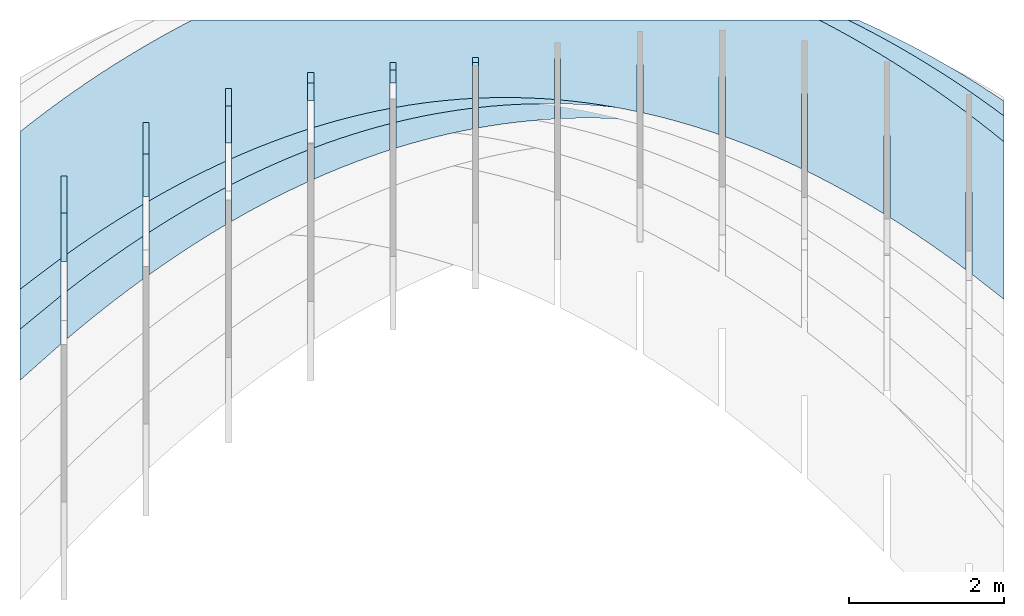
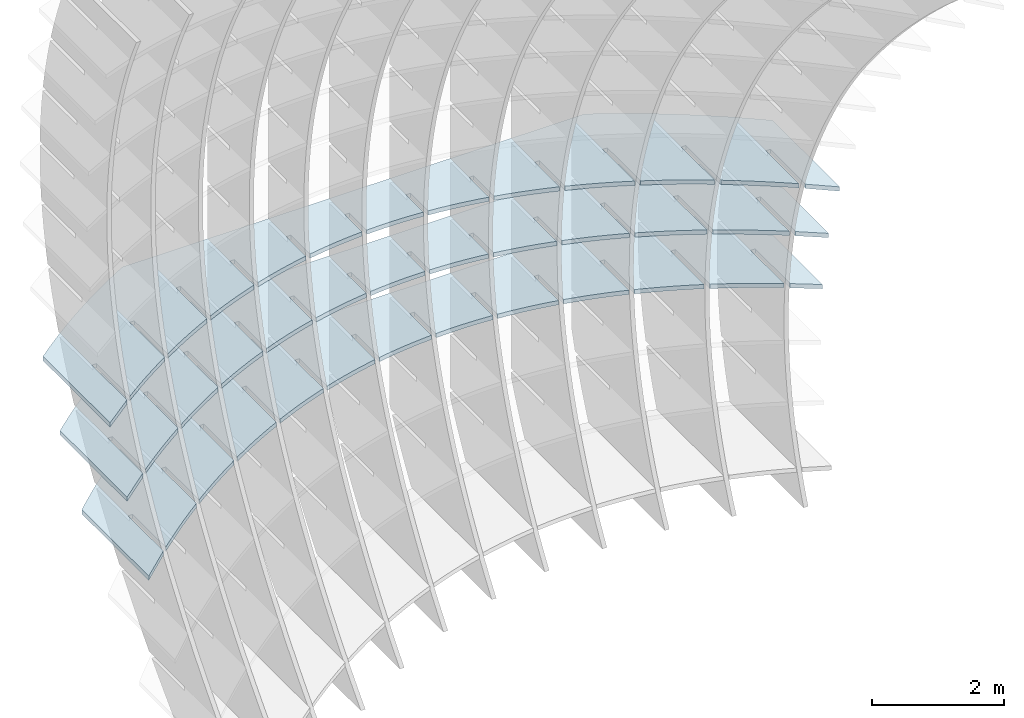
# Not in any storey, part 4 of 9: 3 slabs.
"""IFC2X3 building model written with IfcOpenShell, lengths in metres."""

from ifc_helpers import new_model, si_unit, point, direction, frame, frame_2d, origin_with_axes, place, context, project, spatial, polyline, circle_curve, parameter, trimmed, segment, composite_curve, outline, extrude, material, layer, layer_set, layer_usage, type_object, element, save


model = new_model("IFC2X3")

# Units and contexts
model_context = context("Model", 3, precision=2.54e-06, world=origin_with_axes(), true_north=direction((0.0, 1.0)), identifier="Body")
ifc_project = project(units=[si_unit("LENGTHUNIT", "METRE"), si_unit("AREAUNIT", "SQUARE_METRE"), si_unit("VOLUMEUNIT", "CUBIC_METRE"), si_unit("PLANEANGLEUNIT", "RADIAN")], contexts=[model_context])

# Building
building_placement = place(None, origin_with_axes())
building = spatial("IfcBuilding", under=ifc_project, at=building_placement, Name="Building", CompositionType="ELEMENT")

# Slabs
ifc_material = material(Name="MATERIAL")
ifc_layer = layer(ifc_material, 0.07874, ventilated=True)
ifc_layer_set = layer_set([ifc_layer], Name="SLAB")
ifc_layer_usage_1 = layer_usage(ifc_layer_set, "AXIS3", "NEGATIVE", -0.07874)
slab_type = type_object("IfcSlabType", Name="SLAB", PredefinedType="FLOOR", material=ifc_material)
slab_1_placement = place(None, frame((6.71456553163902, -0.644521735604765, -0.674525377451899), z_axis=(0.0, 0.0, 1.0), x_axis=(-0.79865468, -0.60178958, 0.0)))
element("IfcSlab", 1, at=slab_1_placement, inside=building, type_object=slab_type, material=ifc_layer_usage_1, PredefinedType="FLOOR", context=model_context, shape_type="SweptSolid", body=[
    extrude(outline(composite_curve([segment(polyline([(0.0, 0.0), (0.65981715170106, 0.0)]), True, "CONTINUOUS"), segment(polyline([(0.65981715170106, 0.0), (-0.563019272551403, -1.62286631597352)]), True, "CONTINUOUS"), segment(trimmed(circle_curve(frame_2d((-0.947145737504504, 11.8507513203802), x_axis=(-0.16759298, -0.98585627)), 13.4790921560668), [parameter(0.196889410990906), point((-0.563019272551403, -1.62286631597352))], [parameter(0.0), point((-3.20614692319336, -1.43769625617274))], False, "PARAMETER"), True, "CONTINUOUS"), segment(polyline([(-3.20614692319336, -1.43769625617274), (-9.6696558133236, 3.43258419856068)]), True, "CONTINUOUS"), segment(trimmed(circle_curve(frame_2d((2.6478077793286, 9.33454525857451), x_axis=(-0.97197257, -0.23509427)), 13.6584425799661), [parameter(0.209516548637611), point((-9.6696558133236, 3.43258419856068))], [parameter(0.0), point((-10.627823795437, 6.12352361409473))], False, "PARAMETER"), True, "CONTINUOUS"), segment(polyline([(-10.627823795437, 6.12352361409473), (-9.40498737118473, 7.74638993006891)]), True, "CONTINUOUS"), segment(polyline([(-9.40498737118473, 7.74638993006891), (-9.269961949301, 7.24379688602932)]), True, "CONTINUOUS"), segment(polyline([(-9.269961949301, 7.24379688602932), (-9.91076268291159, 6.39336922031479)]), True, "CONTINUOUS"), segment(polyline([(-9.91076268291159, 6.39336922031479), (-9.84787661316761, 6.345984308875)]), True, "CONTINUOUS"), segment(polyline([(-9.84787661316761, 6.345984308875), (-9.24279514028935, 7.14900777242129)]), True, "CONTINUOUS"), segment(trimmed(circle_curve(frame_2d((4.23850191881597, 11.0342498600031), x_axis=(-0.96089177, -0.27692418)), 14.0299849064409), [parameter(0.0), point((-9.24279514028935, 7.14900777242129))], [parameter(0.0850680879933757), point((-8.86393367696161, 6.01761174932985))], True, "PARAMETER"), True, "CONTINUOUS"), segment(polyline([(-8.86393367696161, 6.01761174932985), (-9.50155817068718, 5.17139937571716)]), True, "CONTINUOUS"), segment(polyline([(-9.50155817068718, 5.17139937571716), (-9.43867210094321, 5.12401446427737)]), True, "CONTINUOUS"), segment(polyline([(-9.43867210094321, 5.12401446427737), (-8.83041447288117, 5.93125310751559)]), True, "CONTINUOUS"), segment(trimmed(circle_curve(frame_2d((2.20317980371444, 10.2436466210628), x_axis=(-0.93138879, -0.36402598)), 11.8463893434332), [parameter(0.0), point((-8.83041447288117, 5.93125310751559))], [parameter(0.0948934985891333), point((-8.37216998538379, 4.90520889880477))], True, "PARAMETER"), True, "CONTINUOUS"), segment(polyline([(-8.37216998538379, 4.90520889880477), (-8.97825059234254, 4.10085945165779)]), True, "CONTINUOUS"), segment(polyline([(-8.97825059234254, 4.10085945165779), (-8.91536452259856, 4.05347454021801)]), True, "CONTINUOUS"), segment(polyline([(-8.91536452259856, 4.05347454021801), (-8.3323098186087, 4.82726555650499)]), True, "CONTINUOUS"), segment(trimmed(circle_curve(frame_2d((0.667414152355688, 9.46203152857244), x_axis=(-0.88903308, -0.45784296)), 10.1230473262445), [parameter(0.0), point((-8.3323098186087, 4.82726555650499))], [parameter(0.105381578793881), point((-7.79486838062499, 3.90632621768747))], True, "PARAMETER"), True, "CONTINUOUS"), segment(polyline([(-7.79486838062499, 3.90632621768747), (-8.26385630761464, 3.28391696145739)]), True, "CONTINUOUS"), segment(polyline([(-8.26385630761464, 3.28391696145739), (-8.20097023787067, 3.2365320500176)]), True, "CONTINUOUS"), segment(polyline([(-8.20097023787067, 3.2365320500176), (-7.74866725115546, 3.83679817490266)]), True, "CONTINUOUS"), segment(trimmed(circle_curve(frame_2d((-0.326331613366641, 8.80592224281057), x_axis=(-0.83096876, -0.55631907)), 8.93214757615724), [parameter(0.0), point((-7.74866725115546, 3.83679817490266))], [parameter(0.114554431580329), point((-7.13202886268566, 3.02096370597877))], True, "PARAMETER"), True, "CONTINUOUS"), segment(polyline([(-7.13202886268566, 3.02096370597877), (-7.50669306629637, 2.52373455596112)]), True, "CONTINUOUS"), segment(polyline([(-7.50669306629637, 2.52373455596112), (-7.44380699655239, 2.47634964452134)]), True, "CONTINUOUS"), segment(polyline([(-7.44380699655239, 2.47634964452134), (-7.07948677052146, 2.95985096270859)]), True, "CONTINUOUS"), segment(trimmed(circle_curve(frame_2d((-0.869203869470965, 8.34399793188824), x_axis=(-0.75557456, -0.65506266)), 8.21928538845114), [parameter(0.0), point((-7.07948677052146, 2.95985096270859))], [parameter(0.121087811880612), point((-6.38365143156546, 2.24912136367815))], True, "PARAMETER"), True, "CONTINUOUS"), segment(polyline([(-6.38365143156546, 2.24912136367815), (-6.70676086838771, 1.82031223516898)]), True, "CONTINUOUS"), segment(polyline([(-6.70676086838771, 1.82031223516898), (-6.64387479864373, 1.7729273237292)]), True, "CONTINUOUS"), segment(polyline([(-6.64387479864373, 1.7729273237292), (-6.32476837670669, 2.19642391992279)]), True, "CONTINUOUS"), segment(trimmed(circle_curve(frame_2d((-1.05234899197816, 8.14493776391442), x_axis=(-0.66329857, -0.74835487)), 7.94878752519032), [parameter(0.0), point((-6.32476837670669, 2.19642391992279))], [parameter(0.123820419877384), point((-5.54973608726407, 1.59079919078546))], True, "PARAMETER"), True, "CONTINUOUS"), segment(polyline([(-5.54973608726407, 1.59079919078546), (-5.86405971388866, 1.17364999908097)]), True, "CONTINUOUS"), segment(polyline([(-5.86405971388866, 1.17364999908097), (-5.80117364414468, 1.12626508764119)]), True, "CONTINUOUS"), segment(polyline([(-5.80117364414468, 1.12626508764119), (-5.48451206971114, 1.54651704654525)]), True, "CONTINUOUS"), segment(trimmed(circle_curve(frame_2d((-0.96691335690673, 8.27742090700019), x_axis=(-0.55728772, -0.83031945)), 8.10640271073547), [parameter(0.0), point((-5.48451206971114, 1.54651704654525))], [parameter(0.122209681178166), point((-4.63028282978231, 1.04599718730138))], True, "PARAMETER"), True, "CONTINUOUS"), segment(polyline([(-4.63028282978231, 1.04599718730138), (-4.97858960279923, 0.583747847697094)]), True, "CONTINUOUS"), segment(polyline([(-4.97858960279923, 0.583747847697094), (-4.91570353305525, 0.536362936257311)]), True, "CONTINUOUS"), segment(polyline([(-4.91570353305525, 0.536362936257311), (-4.55871784953484, 1.01013034257597)]), True, "CONTINUOUS"), segment(trimmed(circle_curve(frame_2d((-0.704043340276491, 8.81012652925522), x_axis=(-0.44304129, -0.89650121)), 8.70048596829722), [parameter(0.0), point((-4.55871784953484, 1.01013034257597))], [parameter(0.11657956097122), point((-3.62529165911954, 0.614715353225459))], True, "PARAMETER"), True, "CONTINUOUS"), segment(polyline([(-3.62529165911954, 0.614715353225459), (-4.05035053511942, 0.0506057810173494)]), True, "CONTINUOUS"), segment(polyline([(-4.05035053511942, 0.0506057810173494), (-3.98746446537544, 0.00322086957756661)]), True, "CONTINUOUS"), segment(polyline([(-3.98746446537544, 0.00322086957756661), (-3.54738571617776, 0.587263808014956)]), True, "CONTINUOUS"), segment(trimmed(circle_curve(frame_2d((-0.354885318106398, 9.81173379879081), x_axis=(-0.32705701, -0.94500461)), 9.76129629723481), [parameter(0.0), point((-3.54738571617776, 0.587263808014956))], [parameter(0.107970086288464), point((-2.53476257527634, 0.296953688557926))], True, "PARAMETER"), True, "CONTINUOUS"), segment(polyline([(-2.53476257527634, 0.296953688557926), (-3.07934251084922, -0.425776200958263)]), True, "CONTINUOUS"), segment(polyline([(-3.07934251084922, -0.425776200958263), (-3.01645644110525, -0.473161112398046)]), True, "CONTINUOUS"), segment(polyline([(-3.01645644110525, -0.473161112398046), (-2.45051566963992, 0.277917442862208)]), True, "CONTINUOUS"), segment(trimmed(circle_curve(frame_2d((-0.0105856664164421, 11.3509218837156), x_axis=(-0.21518724, -0.97657281)), 11.3386368566856), [parameter(0.0), point((-2.45051566963992, 0.277917442862208))], [parameter(0.0977064081270912), point((-1.35869557825283, 0.0927121932986767))], True, "PARAMETER"), True, "CONTINUOUS"), segment(polyline([(-1.35869557825283, 0.0927121932986767), (-1.96778573985251, -0.715631332497445)]), True, "CONTINUOUS"), segment(polyline([(-1.96778573985251, -0.715631332497445), (-1.90489967010853, -0.763016243937229)]), True, "CONTINUOUS"), segment(polyline([(-1.90489967010853, -0.763016243937229), (-1.2681077099213, 0.0820912471177166)]), True, "CONTINUOUS"), segment(trimmed(circle_curve(frame_2d((0.232685907297036, 13.440555051315), x_axis=(-0.11164538, -0.99374811)), 13.4425048517578), [parameter(0.0), point((-1.2681077099213, 0.0820912471177166))], [parameter(0.0873495783940422), point((-0.0970129550590675, 0.00209400290275238))], True, "PARAMETER"), True, "CONTINUOUS"), segment(polyline([(-0.0970129550590675, 0.00209400290275238), (-0.702888576888902, -0.801983401757981)]), True, "CONTINUOUS"), segment(polyline([(-0.702888576888902, -0.801983401757981), (-0.640002507144928, -0.849368313197764)]), True, "CONTINUOUS"), segment(polyline([(-0.640002507144928, -0.849368313197764), (0.0, 0.0)]), True, "CONTINUOUS")], self_intersect="UNKNOWN")), origin_with_axes(), (0.0, 0.0, 1.0), 0.07874),
])
ifc_layer_usage_2 = layer_usage(ifc_layer_set, "AXIS3", "NEGATIVE", -0.07874)
slab_2_placement = place(None, frame((6.71456553163902, -1.12598118468921, -1.73670719563372), z_axis=(0.0, 0.0, 1.0), x_axis=(-0.77311114, -0.63427058, 0.0)))
element("IfcSlab", 2, at=slab_2_placement, inside=building, type_object=slab_type, material=ifc_layer_usage_2, PredefinedType="FLOOR", context=model_context, shape_type="SweptSolid", body=[
    extrude(outline(composite_curve([segment(polyline([(0.0, 0.0), (0.681617468863319, 0.0)]), True, "CONTINUOUS"), segment(polyline([(0.681617468863319, 0.0), (-0.60722034500908, -1.57096183579761)]), True, "CONTINUOUS"), segment(trimmed(circle_curve(frame_2d((-1.049393966451, 12.3123768259553), x_axis=(-0.21974697, -0.9755569)), 13.8903783212849), [parameter(0.253393555882452), point((-0.60722034500908, -1.57096183579761))], [parameter(0.0), point((-4.1017624741084, -1.23847762687843))], False, "PARAMETER"), True, "CONTINUOUS"), segment(polyline([(-4.1017624741084, -1.23847762687843), (-10.112568362786, 3.69286681742569)]), True, "CONTINUOUS"), segment(trimmed(circle_curve(frame_2d((1.65356049293674, 8.99583956676798), x_axis=(-0.97133058, -0.23773284)), 12.9059408114921), [parameter(0.1834032719619), point((-10.112568362786, 3.69286681742569))], [parameter(0.0), point((-10.8823744995443, 5.92767364980279))], False, "PARAMETER"), True, "CONTINUOUS"), segment(polyline([(-10.8823744995443, 5.92767364980279), (-9.59353668567202, 7.49863548560074)]), True, "CONTINUOUS"), segment(polyline([(-9.59353668567202, 7.49863548560074), (-9.46197789100519, 7.01211698228835)]), True, "CONTINUOUS"), segment(polyline([(-9.46197789100519, 7.01211698228835), (-10.1356944095607, 6.19092526413324)]), True, "CONTINUOUS"), segment(polyline([(-10.1356944095607, 6.19092526413324), (-10.0748196384235, 6.14098279884569)]), True, "CONTINUOUS"), segment(polyline([(-10.0748196384235, 6.14098279884569), (-9.43540868750969, 6.92035952915644)]), True, "CONTINUOUS"), segment(trimmed(circle_curve(frame_2d((2.85344007058937, 10.500291075749), x_axis=(-0.96009059, -0.27968922)), 12.7996763114432), [parameter(0.0), point((-9.43540868750969, 6.92035952915644))], [parameter(0.0904359883612016), point((-9.0618762070548, 5.82514918684024))], True, "PARAMETER"), True, "CONTINUOUS"), segment(polyline([(-9.0618762070548, 5.82514918684024), (-9.73224505131122, 5.00803794219949)]), True, "CONTINUOUS"), segment(polyline([(-9.73224505131122, 5.00803794219949), (-9.67137028017406, 4.95809547691193)]), True, "CONTINUOUS"), segment(polyline([(-9.67137028017406, 4.95809547691193), (-9.0286117442338, 5.74155257192177)]), True, "CONTINUOUS"), segment(trimmed(circle_curve(frame_2d((1.10172457082669, 9.80287991487165), x_axis=(-0.92818596, -0.37211667)), 10.9141235856493), [parameter(0.0), point((-9.0286117442338, 5.74155257192177))], [parameter(0.100224490194483), point((-8.57141161919448, 4.74832455439448))], True, "PARAMETER"), True, "CONTINUOUS"), segment(polyline([(-8.57141161919448, 4.74832455439448), (-9.15753824700038, 4.03389597903994)]), True, "CONTINUOUS"), segment(polyline([(-9.15753824700038, 4.03389597903994), (-9.09666347586322, 3.98395351375239)]), True, "CONTINUOUS"), segment(polyline([(-9.09666347586322, 3.98395351375239), (-8.5314639464729, 4.67287409066749)]), True, "CONTINUOUS"), segment(trimmed(circle_curve(frame_2d((-0.180620767954073, 9.12783396944222), x_axis=(-0.88230131, -0.47068504)), 9.46484280449005), [parameter(0.0), point((-8.5314639464729, 4.67287409066749))], [parameter(0.110213642371294), point((-7.99079229367558, 3.78138935151939))], True, "PARAMETER"), True, "CONTINUOUS"), segment(polyline([(-7.99079229367558, 3.78138935151939), (-8.45496548377345, 3.21560957768402)]), True, "CONTINUOUS"), segment(polyline([(-8.45496548377345, 3.21560957768402), (-8.39409071263629, 3.16566711239646)]), True, "CONTINUOUS"), segment(polyline([(-8.39409071263629, 3.16566711239646), (-7.94416141105401, 3.71408503898503)]), True, "CONTINUOUS"), segment(trimmed(circle_curve(frame_2d((-0.96033956442553, 8.59198727510594), x_axis=(-0.81982561, -0.57261328)), 8.51866760770713), [parameter(0.0), point((-7.94416141105401, 3.71408503898503))], [parameter(0.118233031779903), point((-7.32001823049932, 2.92434357821702))], True, "PARAMETER"), True, "CONTINUOUS"), segment(polyline([(-7.32001823049932, 2.92434357821702), (-7.70731535171753, 2.45226789111401)]), True, "CONTINUOUS"), segment(polyline([(-7.70731535171753, 2.45226789111401), (-7.64644058058038, 2.40232542582646)]), True, "CONTINUOUS"), segment(polyline([(-7.64644058058038, 2.40232542582646), (-7.26670413797714, 2.8651854168744)]), True, "CONTINUOUS"), segment(trimmed(circle_curve(frame_2d((-1.32566304058456, 8.26772589031769), x_axis=(-0.73984126, -0.67278147)), 8.03015646722407), [parameter(0.0), point((-7.26670413797714, 2.8651854168744))], [parameter(0.122982293439979), point((-6.55908942966469, 2.17718723448598))], True, "PARAMETER"), True, "CONTINUOUS"), segment(polyline([(-6.55908942966469, 2.17718723448598), (-6.91458785083263, 1.74387091932992)]), True, "CONTINUOUS"), segment(polyline([(-6.91458785083263, 1.74387091932992), (-6.85371307969547, 1.69392845404237)]), True, "CONTINUOUS"), segment(polyline([(-6.85371307969547, 1.69392845404237), (-6.4990921272423, 2.1261752243356)]), True, "CONTINUOUS"), segment(trimmed(circle_curve(frame_2d((-1.36482241842986, 8.22743587353099), x_axis=(-0.64386907, -0.76513569)), 7.97408972562067), [parameter(0.0), point((-6.4990921272423, 2.1261752243356))], [parameter(0.123558271913988), point((-5.70800589117165, 1.53992032032652))], True, "PARAMETER"), True, "CONTINUOUS"), segment(polyline([(-5.70800589117165, 1.53992032032652), (-6.07678298111872, 1.09041866233174)]), True, "CONTINUOUS"), segment(polyline([(-6.07678298111872, 1.09041866233174), (-6.01590820998157, 1.04047619704418)]), True, "CONTINUOUS"), segment(polyline([(-6.01590820998157, 1.04047619704418), (-5.64132537884946, 1.49705446136862)]), True, "CONTINUOUS"), segment(trimmed(circle_curve(frame_2d((-1.16604891995911, 8.54350328320031), x_axis=(-0.5361226, -0.84414013)), 8.34748706990262), [parameter(0.0), point((-5.64132537884946, 1.49705446136862))], [parameter(0.119844445167166), point((-4.766767615022, 1.01254283573971))], True, "PARAMETER"), True, "CONTINUOUS"), segment(polyline([(-4.766767615022, 1.01254283573971), (-5.19390074257583, 0.491911120119467)]), True, "CONTINUOUS"), segment(polyline([(-5.19390074257583, 0.491911120119467), (-5.13302597143867, 0.441968654831912)]), True, "CONTINUOUS"), segment(polyline([(-5.13302597143867, 0.441968654831912), (-4.69340389279864, 0.977823127973469)]), True, "CONTINUOUS"), segment(trimmed(circle_curve(frame_2d((-0.817573767170308, 9.28831417777994), x_axis=(-0.42267062, -0.90628337)), 9.16985935833487), [parameter(0.0), point((-4.69340389279864, 0.977823127973469))], [parameter(0.112565458213444), point((-3.73537460121272, 0.595054780723905))], True, "PARAMETER"), True, "CONTINUOUS"), segment(polyline([(-3.73537460121272, 0.595054780723905), (-4.26594113520394, -0.0516517073068876)]), True, "CONTINUOUS"), segment(polyline([(-4.26594113520394, -0.0516517073068876), (-4.20506636406679, -0.101594172594443)]), True, "CONTINUOUS"), segment(polyline([(-4.20506636406679, -0.101594172594443), (-3.65532766908983, 0.568481224150146)]), True, "CONTINUOUS"), segment(trimmed(circle_curve(frame_2d((-0.407628182061687, 10.5342546157236), x_axis=(-0.30984733, -0.95078632)), 10.4816120539847), [parameter(0.0), point((-3.65532766908983, 0.568481224150146))], [parameter(0.102963694064149), point((-2.61382684974659, 0.287456155280371))], True, "PARAMETER"), True, "CONTINUOUS"), segment(polyline([(-2.61382684974659, 0.287456155280371), (-3.25746285440166, -0.497070484592322)]), True, "CONTINUOUS"), segment(polyline([(-3.25746285440166, -0.497070484592322), (-3.1965880832645, -0.547012949879877)]), True, "CONTINUOUS"), segment(polyline([(-3.1965880832645, -0.547012949879877), (-2.52709670772305, 0.269028749898648)]), True, "CONTINUOUS"), segment(trimmed(circle_curve(frame_2d((-0.0244433866311643, 12.353710655486), x_axis=(-0.20279009, -0.97922223)), 12.3411024793088), [parameter(0.0), point((-2.52709670772305, 0.269028749898648))], [parameter(0.0923396645129913), point((-1.40212436062262, 0.0897469594085938))], True, "PARAMETER"), True, "CONTINUOUS"), segment(polyline([(-1.40212436062262, 0.0897469594085938), (-2.04241876032704, -0.690706604868079)]), True, "CONTINUOUS"), segment(polyline([(-2.04241876032704, -0.690706604868079), (-1.98154398918988, -0.740649070155635)]), True, "CONTINUOUS"), segment(polyline([(-1.98154398918988, -0.740649070155635), (-1.30871100869828, 0.0794657052189753)]), True, "CONTINUOUS"), segment(trimmed(circle_curve(frame_2d((0.238574499663533, 14.7577742919088), x_axis=(-0.10483223, -0.99448992)), 14.7596353413788), [parameter(0.0), point((-1.30871100869828, 0.0794657052189753))], [parameter(0.0820714178844788), point((-0.10018522636932, 0.00202702996043339))], True, "PARAMETER"), True, "CONTINUOUS"), segment(polyline([(-0.10018522636932, 0.00202702996043339), (-0.737091584691164, -0.774296857444782)]), True, "CONTINUOUS"), segment(polyline([(-0.737091584691164, -0.774296857444782), (-0.676216813554006, -0.824239322732338)]), True, "CONTINUOUS"), segment(polyline([(-0.676216813554006, -0.824239322732338), (0.0, 0.0)]), True, "CONTINUOUS")], self_intersect="UNKNOWN")), origin_with_axes(), (0.0, 0.0, 1.0), 0.07874),
])
ifc_layer_usage_3 = layer_usage(ifc_layer_set, "AXIS3", "NEGATIVE", -0.07874)
slab_3_placement = place(None, frame((6.71456553163902, -1.74957987344307, -2.79888901381554), z_axis=(0.0, 0.0, 1.0), x_axis=(-0.74799089, -0.66370899, 0.0)))
element("IfcSlab", 3, at=slab_3_placement, inside=building, type_object=slab_type, material=ifc_layer_usage_3, PredefinedType="FLOOR", context=model_context, shape_type="SweptSolid", body=[
    extrude(outline(composite_curve([segment(polyline([(0.0, 0.0), (0.704508653460496, 0.0)]), True, "CONTINUOUS"), segment(polyline([(0.704508653460496, 0.0), (-0.644148010755746, -1.51991749844033)]), True, "CONTINUOUS"), segment(trimmed(circle_curve(frame_2d((-1.04670349128989, 15.0304492640026), x_axis=(-0.13348426, -0.99105093)), 16.5552617281118), [parameter(0.158202135905738), point((-0.644148010755746, -1.51991749844033))], [parameter(0.0), point((-3.25657032699311, -1.37665832553745))], False, "PARAMETER"), True, "CONTINUOUS"), segment(trimmed(circle_curve(frame_2d((-1.66784876304802, 10.3662812986743), x_axis=(-0.30292077, -0.95301574)), 11.8499226674956), [parameter(0.173280793712937), point((-3.25657032699311, -1.37665832553745))], [parameter(0.0), point((-5.25743643561738, -0.926881569475817))], False, "PARAMETER"), True, "CONTINUOUS"), segment(polyline([(-5.25743643561738, -0.926881569475817), (-10.4735632450059, 3.70150397783012)]), True, "CONTINUOUS"), segment(trimmed(circle_curve(frame_2d((0.424004711913303, 8.6578009544475), x_axis=(-0.96974088, -0.24413651)), 11.9717111181359), [parameter(0.180215594323643), point((-10.4735632450059, 3.70150397783012))], [parameter(0.0), point((-11.1854529168979, 5.73506924234393))], False, "PARAMETER"), True, "CONTINUOUS"), segment(polyline([(-11.1854529168979, 5.73506924234393), (-9.83679625268173, 7.2549867407845)]), True, "CONTINUOUS"), segment(polyline([(-9.83679625268173, 7.2549867407845), (-9.70594004019233, 6.78427639655512)]), True, "CONTINUOUS"), segment(polyline([(-9.70594004019233, 6.78427639655512), (-10.4091774249853, 5.99173754284669)]), True, "CONTINUOUS"), segment(polyline([(-10.4091774249853, 5.99173754284669), (-10.3502806219207, 5.93947709710831)]), True, "CONTINUOUS"), segment(polyline([(-10.3502806219207, 5.93947709710831), (-9.67944433072152, 6.69550036428652)]), True, "CONTINUOUS"), segment(trimmed(circle_curve(frame_2d((1.5526870904251, 10.0697566017542), x_axis=(-0.95771787, -0.28770902)), 11.7280169431153), [parameter(0.0), point((-9.67944433072152, 6.69550036428652))], [parameter(0.0958647745136821), point((-9.3048948060391, 5.63587604635226))], True, "PARAMETER"), True, "CONTINUOUS"), segment(polyline([(-9.3048948060391, 5.63587604635226), (-10.0046291408711, 4.8472850817355)]), True, "CONTINUOUS"), segment(polyline([(-10.0046291408711, 4.8472850817355), (-9.9457323378065, 4.79502463599712)]), True, "CONTINUOUS"), segment(polyline([(-9.9457323378065, 4.79502463599712), (-9.27139309006283, 5.55499568698831)]), True, "CONTINUOUS"), segment(trimmed(circle_curve(frame_2d((0.0700366133711062, 9.4554800498847), x_axis=(-0.92278831, -0.38530733)), 10.123047326245), [parameter(0.0), point((-9.27139309006283, 5.55499568698831))], [parameter(0.105381578793875), point((-8.80929265305124, 4.59404004224781))], True, "PARAMETER"), True, "CONTINUOUS"), segment(polyline([(-8.80929265305124, 4.59404004224781), (-9.41468173409906, 3.91177488013322)]), True, "CONTINUOUS"), segment(polyline([(-9.41468173409906, 3.91177488013322), (-9.3557849310345, 3.85951443439484)]), True, "CONTINUOUS"), segment(polyline([(-9.3557849310345, 3.85951443439484), (-8.76879753924558, 4.52104114598552)]), True, "CONTINUOUS"), segment(trimmed(circle_curve(frame_2d((-0.972978893519258, 8.88091178227807), x_axis=(-0.87278211, -0.48811001)), 8.93214757615772), [parameter(0.0), point((-8.76879753924558, 4.52104114598552))], [parameter(0.114554431580324), point((-8.21935140910577, 3.65852289522527))], True, "PARAMETER"), True, "CONTINUOUS"), segment(polyline([(-8.21935140910577, 3.65852289522527), (-8.72071159830374, 3.09349686243145)]), True, "CONTINUOUS"), segment(polyline([(-8.72071159830374, 3.09349686243145), (-8.66181479523918, 3.04123641669307)]), True, "CONTINUOUS"), segment(polyline([(-8.66181479523918, 3.04123641669307), (-8.17186289747026, 3.59340546206371)]), True, "CONTINUOUS"), segment(trimmed(circle_curve(frame_2d((-1.55104050042463, 8.4638636626414), x_axis=(-0.80552288, -0.59256468)), 8.21928538845048), [parameter(0.0), point((-8.17186289747026, 3.59340546206371))], [parameter(0.121087811880622), point((-7.53507107420211, 2.82932460528348))], True, "PARAMETER"), True, "CONTINUOUS"), segment(polyline([(-7.53507107420211, 2.82932460528348), (-7.97957191702939, 2.32837827327018)]), True, "CONTINUOUS"), segment(polyline([(-7.97957191702939, 2.32837827327018), (-7.92067511396483, 2.2761178275318)]), True, "CONTINUOUS"), segment(polyline([(-7.92067511396483, 2.2761178275318), (-7.48058916473687, 2.77208863522289)]), True, "CONTINUOUS"), segment(trimmed(circle_curve(frame_2d((-1.74951258422979, 8.28008140473365), x_axis=(-0.7210001, -0.69293496)), 7.94878752519022), [parameter(0.0), point((-7.48058916473687, 2.77208863522289))], [parameter(0.123820419877384), point((-6.75645164834047, 2.10644517242274))], True, "PARAMETER"), True, "CONTINUOUS"), segment(polyline([(-6.75645164834047, 2.10644517242274), (-7.19126269027601, 1.61641911264941)]), True, "CONTINUOUS"), segment(polyline([(-7.19126269027601, 1.61641911264941), (-7.13236588721145, 1.56415866691103)]), True, "CONTINUOUS"), segment(polyline([(-7.13236588721145, 1.56415866691103), (-6.69497634104542, 2.05709066546305)]), True, "CONTINUOUS"), segment(trimmed(circle_curve(frame_2d((-1.65375952182091, 8.40531072231251), x_axis=(-0.62188088, -0.78311185)), 8.10640271073537), [parameter(0.0), point((-6.69497634104542, 2.05709066546305))], [parameter(0.122209681178168), point((-5.88349313152119, 1.4898845966432))], True, "PARAMETER"), True, "CONTINUOUS"), segment(polyline([(-5.88349313152119, 1.4898845966432), (-6.35578391804359, 0.957619380569116)]), True, "CONTINUOUS"), segment(polyline([(-6.35578391804359, 0.957619380569116), (-6.29688711497902, 0.905358934830737)]), True, "CONTINUOUS"), segment(polyline([(-6.29688711497902, 0.905358934830737), (-5.8150244263959, 1.44841155278419)]), True, "CONTINUOUS"), segment(trimmed(circle_curve(frame_2d((-1.34914569008331, 8.91529732913625), x_axis=(-0.51329072, -0.85821479)), 8.70048596829727), [parameter(0.0), point((-5.8150244263959, 1.44841155278419))], [parameter(0.116579560971219), point((-4.91619552374262, 0.979642877943917))], True, "PARAMETER"), True, "CONTINUOUS"), segment(polyline([(-4.91619552374262, 0.979642877943917), (-5.47313560033213, 0.351979077029319)]), True, "CONTINUOUS"), segment(polyline([(-5.47313560033213, 0.351979077029319), (-5.41423879726757, 0.29971863129094)]), True, "CONTINUOUS"), segment(polyline([(-5.41423879726757, 0.29971863129094), (-4.8407334207883, 0.946051297186317)]), True, "CONTINUOUS"), segment(trimmed(circle_curve(frame_2d((-0.921035465902053, 9.8857869389638), x_axis=(-0.40155506, -0.91583488)), 9.7612962972346), [parameter(0.0), point((-4.8407334207883, 0.946051297186317))], [parameter(0.107970086288466), point((-3.85455882500707, 0.575720016326171))], True, "PARAMETER"), True, "CONTINUOUS"), segment(polyline([(-3.85455882500707, 0.575720016326171), (-4.52981626743488, -0.185285827436894)]), True, "CONTINUOUS"), segment(polyline([(-4.52981626743488, -0.185285827436894), (-4.47091946437032, -0.237546273175274)]), True, "CONTINUOUS"), segment(polyline([(-4.47091946437032, -0.237546273175274), (-3.77210332422264, 0.550009898669427)]), True, "CONTINUOUS"), segment(trimmed(circle_curve(frame_2d((-0.454793226162682, 11.3925252655535), x_axis=(-0.29256692, -0.95624505)), 11.3386368566864), [parameter(0.0), point((-3.77210332422264, 0.550009898669427))], [parameter(0.0977064081270835), point((-2.69858303531252, 0.278116011789121))], True, "PARAMETER"), True, "CONTINUOUS"), segment(polyline([(-2.69858303531252, 0.278116011789121), (-3.37034377882601, -0.478949100423303)]), True, "CONTINUOUS"), segment(polyline([(-3.37034377882601, -0.478949100423303), (-3.31144697576145, -0.531209546161682)]), True, "CONTINUOUS"), segment(polyline([(-3.31144697576145, -0.531209546161682), (-2.60913413669891, 0.260287357233521)]), True, "CONTINUOUS"), segment(trimmed(circle_curve(frame_2d((-0.0357833477509645, 13.5112580226616), x_axis=(-0.19063931, -0.98166015)), 13.498531692707), [parameter(0.0), point((-2.60913413669891, 0.260287357233521))], [parameter(0.0869815694130267), point((-1.44826815466118, 0.0868308643333039))], True, "PARAMETER"), True, "CONTINUOUS"), segment(polyline([(-1.44826815466118, 0.0868308643333039), (-2.11653219925907, -0.666293516328728)]), True, "CONTINUOUS"), segment(polyline([(-2.11653219925907, -0.666293516328728), (-2.05763539619451, -0.718553962067108)]), True, "CONTINUOUS"), segment(polyline([(-2.05763539619451, -0.718553962067108), (-1.35182585821711, 0.076883672878595)]), True, "CONTINUOUS"), segment(trimmed(circle_curve(frame_2d((0.245291224014944, 16.2502242339312), x_axis=(-0.09827199, -0.99515959)), 16.2520068877091), [parameter(0.0), point((-1.35182585821711, 0.076883672878595))], [parameter(0.076966032819889), point((-0.10352847400683, 0.00196116687018835))], True, "PARAMETER"), True, "CONTINUOUS"), segment(polyline([(-0.10352847400683, 0.00196116687018835), (-0.768247228003128, -0.747167720077841)]), True, "CONTINUOUS"), segment(polyline([(-0.768247228003128, -0.747167720077841), (-0.709350424938565, -0.79942816581622)]), True, "CONTINUOUS"), segment(polyline([(-0.709350424938565, -0.79942816581622), (0.0, 0.0)]), True, "CONTINUOUS")], self_intersect="UNKNOWN")), origin_with_axes(), (0.0, 0.0, 1.0), 0.07874),
])

save(model, "model.ifc")
